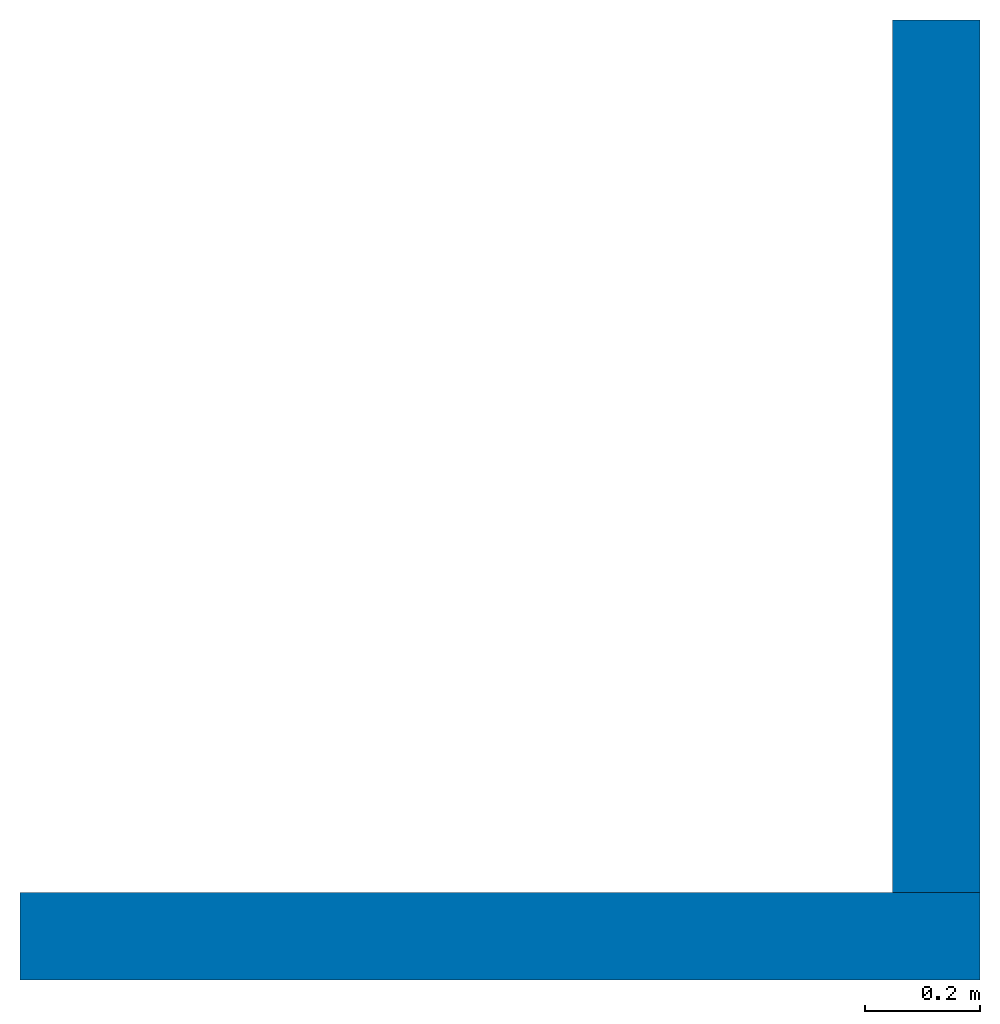
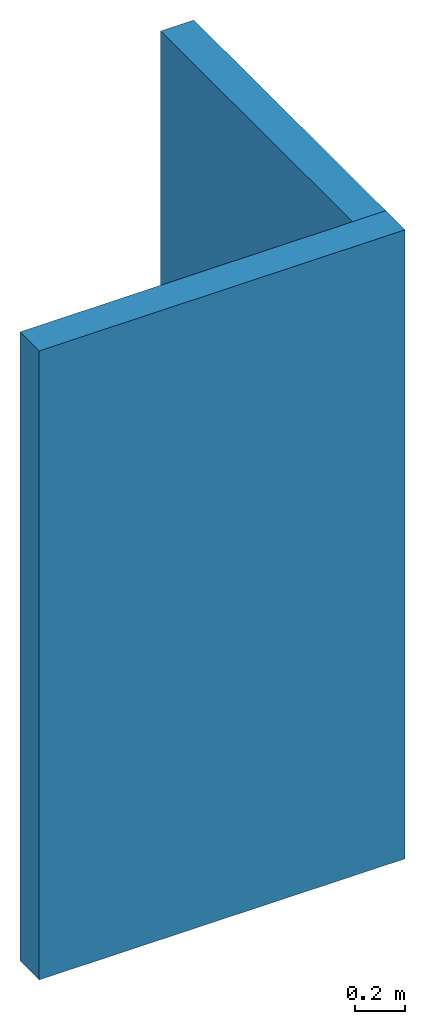
# One storey: 2 walls.
"""IFC2X3 building model written with IfcOpenShell, lengths in feet."""

from ifc_helpers import new_model, entity, si_unit, converted_unit, derived_unit, direction, frame, frame_2d, origin, place, context, subcontext, project, spatial, rectangle, extrude, material, layer, layer_set, layer_usage, type_object, element, save


model = new_model("IFC2X3")

# Units and contexts
model_context = context("Model", 3, precision=0.0001, world=origin(), true_north=direction((6.12303176911189e-17, 1.0)))
body_context = subcontext(model_context, "Body", "Model", "MODEL_VIEW")
ifc_project = project(units=[converted_unit("LENGTHUNIT", "FOOT", entity("IfcRatioMeasure", 0.3048), si_unit("LENGTHUNIT", "METRE"), dimensions=[1, 0, 0, 0, 0, 0, 0]), converted_unit("AREAUNIT", "SQUARE FOOT", entity("IfcRatioMeasure", 0.09290304), si_unit("AREAUNIT", "SQUARE_METRE"), dimensions=[2, 0, 0, 0, 0, 0, 0]), converted_unit("VOLUMEUNIT", "CUBIC FOOT", entity("IfcRatioMeasure", 0.028316846592), si_unit("VOLUMEUNIT", "CUBIC_METRE"), dimensions=[3, 0, 0, 0, 0, 0, 0]), converted_unit("PLANEANGLEUNIT", "DEGREE", entity("IfcRatioMeasure", 0.0174532925199433), si_unit("PLANEANGLEUNIT", "RADIAN"), dimensions=[0, 0, 0, 0, 0, 0, 0]), si_unit("MASSUNIT", "GRAM", prefix="KILO"), derived_unit("MASSDENSITYUNIT", [(si_unit("MASSUNIT", "GRAM", prefix="KILO"), 1), (si_unit("LENGTHUNIT", "METRE"), -3)]), si_unit("TIMEUNIT", "SECOND"), si_unit("FREQUENCYUNIT", "HERTZ"), si_unit("THERMODYNAMICTEMPERATUREUNIT", "DEGREE_CELSIUS"), derived_unit("THERMALTRANSMITTANCEUNIT", [(si_unit("MASSUNIT", "GRAM", prefix="KILO"), 1), (si_unit("THERMODYNAMICTEMPERATUREUNIT", "KELVIN"), -1), (si_unit("TIMEUNIT", "SECOND"), -3)]), derived_unit("VOLUMETRICFLOWRATEUNIT", [(si_unit("LENGTHUNIT", "METRE"), 3), (si_unit("TIMEUNIT", "SECOND"), -1)]), si_unit("ELECTRICCURRENTUNIT", "AMPERE"), si_unit("ELECTRICVOLTAGEUNIT", "VOLT"), si_unit("POWERUNIT", "WATT"), si_unit("FORCEUNIT", "NEWTON"), si_unit("ILLUMINANCEUNIT", "LUX"), si_unit("LUMINOUSFLUXUNIT", "LUMEN"), si_unit("LUMINOUSINTENSITYUNIT", "CANDELA"), derived_unit("USERDEFINED", [(si_unit("MASSUNIT", "GRAM", prefix="KILO"), -1), (si_unit("LENGTHUNIT", "METRE"), -2), (si_unit("TIMEUNIT", "SECOND"), 3), (si_unit("LUMINOUSFLUXUNIT", "LUMEN"), 1)]), derived_unit("LINEARVELOCITYUNIT", [(si_unit("LENGTHUNIT", "METRE"), 1), (si_unit("TIMEUNIT", "SECOND"), -1)]), si_unit("PRESSUREUNIT", "PASCAL"), derived_unit("USERDEFINED", [(si_unit("LENGTHUNIT", "METRE"), -2), (si_unit("MASSUNIT", "GRAM", prefix="KILO"), 1), (si_unit("TIMEUNIT", "SECOND"), -2)])], contexts=[model_context])

# Site, building, storey
site_placement = place(None, origin())
site = spatial("IfcSite", under=ifc_project, at=site_placement, CompositionType="ELEMENT")
building_placement = place(site_placement, origin())
building = spatial("IfcBuilding", under=site, at=building_placement, CompositionType="ELEMENT")
storey_placement = place(building_placement, origin())
storey = spatial("IfcBuildingStorey", under=building, at=storey_placement, Name="Level 1", CompositionType="ELEMENT", Elevation=0.0)

# Walls
ifc_material = material(Name="Wall Material")
ifc_layer = layer(ifc_material, 0.5)
ifc_layer_set = layer_set([ifc_layer], Name="Basic Wall:Wall Type")
ifc_layer_usage_1 = layer_usage(ifc_layer_set, "AXIS2", "NEGATIVE", 0.25)
wall_type = type_object("IfcWallType", Name="Basic Wall:Wall Type", PredefinedType="STANDARD", material=ifc_layer_set)
wall_1_placement = place(storey_placement, frame((0.0, -0.250000000000003, 0.0)))
element("IfcWallStandardCase", 1, at=wall_1_placement, inside=storey, type_object=wall_type, material=ifc_layer_usage_1, Name="Basic Wall:Wall Type", ObjectType="Basic Wall:Wall Type", context=body_context, shape_type="SweptSolid", body=[
    extrude(rectangle(XDim=5.5, YDim=0.5, at=frame_2d((2.75, 0.0), x_axis=(-1.0, 0.0))), origin(), (0.0, 0.0, 1.0), 10.0),
])
ifc_layer_usage_2 = layer_usage(ifc_layer_set, "AXIS2", "NEGATIVE", 0.25)
wall_2_placement = place(storey_placement, frame((5.25, 0.0, 0.0), z_axis=(0.0, 0.0, 1.0), x_axis=(0.0, 1.0, 0.0)))
element("IfcWallStandardCase", 2, at=wall_2_placement, inside=storey, type_object=wall_type, material=ifc_layer_usage_2, Name="Basic Wall:Wall Type", ObjectType="Basic Wall:Wall Type", context=body_context, shape_type="SweptSolid", body=[
    extrude(rectangle(XDim=5.0, YDim=0.5, at=frame_2d((2.5, 0.0), x_axis=(-1.0, 0.0))), origin(), (0.0, 0.0, 1.0), 10.0),
])

save(model, "model.ifc")
